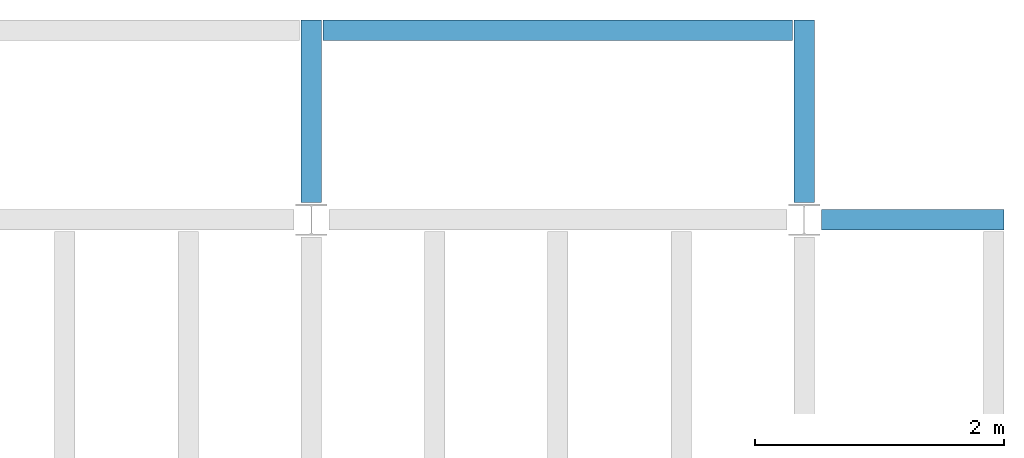
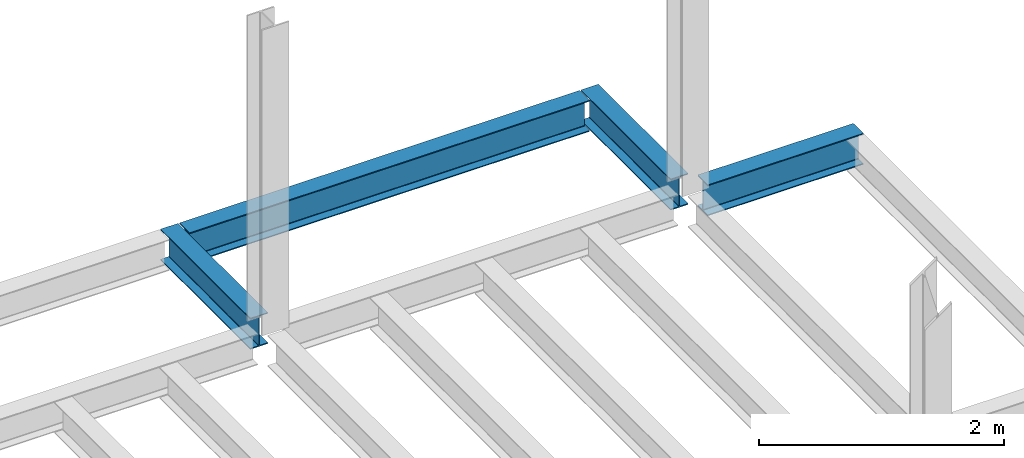
# One storey, part 3 of 3: 4 beams.
"""IFC4 building model written with IfcOpenShell, lengths in feet."""

from ifc_helpers import new_model, entity, si_unit, converted_unit, derived_unit, direction, frame, origin, place, context, subcontext, project, spatial, line, arc, indexed_curve, outline, extrude, source, transform, mapped, material, type_object, type_shapes, element, save


model = new_model("IFC4")

# Units and contexts
model_context = context("Model", 3, precision=0.0001, world=origin(), true_north=direction((6.123233995736766e-17, 1.0)))
plan_context = context("Plan", 3, precision=0.0001, world=origin(), true_north=direction((6.123233995736766e-17, 1.0)))
body_context = subcontext(model_context, "Body", "Model", "MODEL_VIEW")
ifc_project = project(units=[converted_unit("LENGTHUNIT", "FOOT", entity("IfcLengthMeasure", 0.3048), si_unit("LENGTHUNIT", "METRE"), dimensions=[1, 0, 0, 0, 0, 0, 0]), converted_unit("AREAUNIT", "SQUARE FOOT", entity("IfcAreaMeasure", 0.09290304), si_unit("AREAUNIT", "SQUARE_METRE"), dimensions=[2, 0, 0, 0, 0, 0, 0]), converted_unit("PLANEANGLEUNIT", "DEGREE", entity("IfcPlaneAngleMeasure", 0.017453292519943278), si_unit("PLANEANGLEUNIT", "RADIAN"), dimensions=[0, 0, 0, 0, 0, 0, 0]), converted_unit("VOLUMEUNIT", "CUBIC FOOT", entity("IfcVolumeMeasure", 0.028316846592000004), si_unit("VOLUMEUNIT", "CUBIC_METRE"), dimensions=[3, 0, 0, 0, 0, 0, 0]), si_unit("PRESSUREUNIT", "PASCAL"), derived_unit("MASSDENSITYUNIT", [(si_unit("MASSUNIT", "GRAM", prefix="KILO"), 1), (si_unit("LENGTHUNIT", "METRE"), -3)]), derived_unit("VAPORPERMEABILITYUNIT", [(si_unit("LENGTHUNIT", "METRE"), -1), (si_unit("TIMEUNIT", "SECOND"), 1)]), derived_unit("USERDEFINED", [(si_unit("MASSUNIT", "GRAM", prefix="KILO"), 1), (si_unit("LENGTHUNIT", "METRE"), 3), (si_unit("TIMEUNIT", "SECOND"), -3), (si_unit("ELECTRICCURRENTUNIT", "AMPERE"), -2)]), derived_unit("MODULUSOFELASTICITYUNIT", [(si_unit("MASSUNIT", "GRAM", prefix="KILO"), 1), (si_unit("LENGTHUNIT", "METRE"), -1), (si_unit("TIMEUNIT", "SECOND"), -2)]), derived_unit("THERMALEXPANSIONCOEFFICIENTUNIT", [(si_unit("THERMODYNAMICTEMPERATUREUNIT", "KELVIN"), -1)]), derived_unit("SPECIFICHEATCAPACITYUNIT", [(si_unit("TIMEUNIT", "SECOND"), -2), (si_unit("THERMODYNAMICTEMPERATUREUNIT", "KELVIN"), -1), (si_unit("LENGTHUNIT", "METRE"), 2)]), derived_unit("THERMALCONDUCTANCEUNIT", [(si_unit("MASSUNIT", "GRAM", prefix="KILO"), 1), (si_unit("TIMEUNIT", "SECOND"), -3), (si_unit("THERMODYNAMICTEMPERATUREUNIT", "KELVIN"), -1), (si_unit("LENGTHUNIT", "METRE"), 1)])], contexts=[model_context, plan_context])

# Site, building, storey
site_placement = place(None, origin())
site = spatial("IfcSite", under=ifc_project, at=site_placement, CompositionType="ELEMENT")
building_placement = place(site_placement, origin())
building = spatial("IfcBuilding", under=site, at=building_placement, CompositionType="ELEMENT")
storey_placement = place(building_placement, frame((0.0, 0.0, 79.875)))
storey = spatial("IfcBuildingStorey", under=building, at=storey_placement, Name="STR 09", CompositionType="ELEMENT", Elevation=79.875)

# Beams
ifc_material = material(Name="Steel ASTM A992", Category="Metal")
beam_type_1 = type_object("IfcBeamType", Name="W12X26", PredefinedType="JOIST", material=ifc_material)
shared_shape_1 = source(origin(), body_context, "Body", "SweptSolid", [
    extrude(outline(indexed_curve([(0.47666666666666574, -0.2704166666666672), (0.5083333333333351, -0.2704166666666672), (0.5083333333333351, 0.27041666666666686), (0.47666666666666574, 0.27041666666666686), (0.47666666666666574, 0.03458333333333307), (0.46934433619632937, 0.016905663803669473), (0.4516666666666659, 0.00958333333333318), (-0.45166666666666705, 0.00958333333333318), (-0.4693443361963307, 0.01690566380366946), (-0.4766666666666671, 0.03458333333333323), (-0.4766666666666671, 0.27041666666666686), (-0.5083333333333312, 0.27041666666666686), (-0.5083333333333312, -0.27041666666666553), (-0.4766666666666671, -0.27041666666666553), (-0.47666666666666707, -0.034583333333333535), (-0.46934433619633054, -0.016905663803669885), (-0.45166666666666694, -0.00958333333333376), (0.4516666666666658, -0.009583333333333756), (0.4693443361963295, -0.01690566380367015), (0.47666666666666574, -0.0345833333333337)], segments=[line(1, 2, 3, 4, 5), arc(5, 6, 7), line(7, 8), arc(8, 9, 10), line(10, 11, 12, 13, 14, 15), arc(15, 16, 17), line(17, 18), arc(18, 19, 20), line(20, 1)], self_intersect=False)), frame((-2.77041666666672, 0.0, 0.0), z_axis=(1.0, 0.0, 0.0), x_axis=(0.0, 0.0, -1.0)), (0.0, 0.0, 1.0), 4.812083333333389),
])
type_shapes(beam_type_1, [shared_shape_1])
beam_1_placement = place(storey_placement, frame((41.50000000000015, 39.0, -0.50833333333334), z_axis=(0.0, 0.0, 1.0), x_axis=(-1.0, 0.0, 0.0)))
element("IfcBeam", 1, at=beam_1_placement, inside=storey, type_object=beam_type_1, material=ifc_material, Name="W12X26", ObjectType="W Shapes:W12X26", PredefinedType="JOIST", context=body_context, shape_type="MappedRepresentation", body=[
    mapped(shared_shape_1, transform((0.0, 0.0, 0.0), scale=1.0)),
])
beam_type_2 = type_object("IfcBeamType", Name="W12X26", PredefinedType="JOIST", material=ifc_material)
shared_shape_2 = source(origin(), body_context, "Body", "SweptSolid", [
    extrude(outline(indexed_curve([(-0.2704166666666623, -0.5083333333333258), (0.2704166666666694, -0.5083333333333258), (0.2704166666666694, -0.47666666666665947), (0.03458333333333741, -0.4766666666666737), (0.01690566380367642, -0.469344336196329), (0.009583333333338828, -0.451666666666668), (0.009583333333338828, 0.451666666666668), (0.01690566380367642, 0.469344336196329), (0.03458333333333741, 0.4766666666666737), (0.2704166666666694, 0.4766666666666737), (0.2704166666666694, 0.50833333333334), (-0.2704166666666623, 0.50833333333334), (-0.2704166666666623, 0.4766666666666737), (-0.0345833333333303, 0.4766666666666737), (-0.016905663803669313, 0.469344336196329), (-0.009583333333331723, 0.451666666666668), (-0.009583333333331723, -0.451666666666668), (-0.016905663803669313, -0.469344336196329), (-0.0345833333333303, -0.47666666666665947), (-0.2704166666666623, -0.47666666666665947)], segments=[line(1, 2, 3, 4), arc(4, 5, 6), line(6, 7), arc(7, 8, 9), line(9, 10, 11, 12, 13, 14), arc(14, 15, 16), line(16, 17), arc(17, 18, 19), line(19, 20, 1)], self_intersect=False)), frame((39.0, 44.270416666666286, 79.36666666666665), z_axis=(0.0, -1.0, 0.0), x_axis=(-1.0, 0.0, 0.0)), (0.0, 0.0, 1.0), 4.812083333333393),
])
type_shapes(beam_type_2, [shared_shape_2])
beam_2_placement = place(storey_placement, frame((0.0, 0.0, -79.875)))
element("IfcBeam", 2, at=beam_2_placement, inside=storey, type_object=beam_type_2, material=ifc_material, Name="W12X26", ObjectType="W Shapes:W12X26", PredefinedType="JOIST", context=body_context, shape_type="MappedRepresentation", body=[
    mapped(shared_shape_2, transform((0.0, 0.0, 0.0), scale=1.0)),
])
beam_type_3 = type_object("IfcBeamType", Name="W12X26", PredefinedType="JOIST", material=ifc_material)
shared_shape_3 = source(origin(), body_context, "Body", "SweptSolid", [
    extrude(outline(indexed_curve([(-0.2704166666666694, -0.5083333333333258), (0.27041666666666586, -0.5083333333333258), (0.2704166666666623, -0.47666666666665947), (0.034583333333333854, -0.4766666666666737), (0.016905663803669313, -0.469344336196329), (0.009583333333335275, -0.451666666666668), (0.009583333333335275, 0.451666666666668), (0.016905663803669313, 0.469344336196329), (0.034583333333333854, 0.4766666666666737), (0.2704166666666694, 0.4766666666666737), (0.27041666666666586, 0.50833333333334), (-0.27041666666666586, 0.50833333333334), (-0.27041666666666586, 0.4766666666666737), (-0.0345833333333303, 0.4766666666666737), (-0.01690566380366576, 0.469344336196329), (-0.009583333333331723, 0.451666666666668), (-0.009583333333331723, -0.451666666666668), (-0.01690566380366576, -0.469344336196329), (-0.034583333333333854, -0.47666666666665947), (-0.27041666666666586, -0.47666666666665947)], segments=[line(1, 2, 3, 4), arc(4, 5, 6), line(6, 7), arc(7, 8, 9), line(9, 10, 11, 12, 13, 14), arc(14, 15, 16), line(16, 17), arc(17, 18, 19), line(19, 20, 1)], self_intersect=False)), frame((26.0, 44.27041666666632, 79.36666666666665), z_axis=(0.0, -1.0, 0.0), x_axis=(-1.0, 0.0, 0.0)), (0.0, 0.0, 1.0), 4.812083333333393),
])
type_shapes(beam_type_3, [shared_shape_3])
beam_3_placement = place(storey_placement, frame((0.0, 0.0, -79.875)))
element("IfcBeam", 3, at=beam_3_placement, inside=storey, type_object=beam_type_3, material=ifc_material, Name="W12X26", ObjectType="W Shapes:W12X26", PredefinedType="JOIST", context=body_context, shape_type="MappedRepresentation", body=[
    mapped(shared_shape_3, transform((0.0, 0.0, 0.0), scale=1.0)),
])
beam_type_4 = type_object("IfcBeamType", Name="W12X26", PredefinedType="JOIST", material=ifc_material)
shared_shape_4 = source(origin(), body_context, "Body", "SweptSolid", [
    extrude(outline(indexed_curve([(-0.5083333333333258, -0.2704166666666694), (-0.47666666666665947, -0.2704166666666694), (-0.4766666666666737, -0.03458333333333741), (-0.469344336196329, -0.01690566380367642), (-0.451666666666668, -0.009583333333338828), (0.451666666666668, -0.009583333333338828), (0.469344336196329, -0.01690566380367642), (0.4766666666666737, -0.03458333333333741), (0.4766666666666737, -0.2704166666666694), (0.50833333333334, -0.2704166666666694), (0.50833333333334, 0.2704166666666623), (0.4766666666666737, 0.2704166666666623), (0.4766666666666737, 0.0345833333333303), (0.469344336196329, 0.016905663803669313), (0.451666666666668, 0.009583333333331723), (-0.451666666666668, 0.009583333333331723), (-0.469344336196329, 0.016905663803669313), (-0.47666666666665947, 0.0345833333333303), (-0.47666666666665947, 0.2704166666666623), (-0.5083333333333258, 0.2704166666666623)], segments=[line(1, 2, 3), arc(3, 4, 5), line(5, 6), arc(6, 7, 8), line(8, 9, 10, 11, 12, 13), arc(13, 14, 15), line(15, 16), arc(16, 17, 18), line(18, 19, 20, 1)], self_intersect=False)), frame((26.312083333333604, 44.0, 79.36666666666665), z_axis=(1.0, 0.0, 0.0), x_axis=(0.0, 0.0, -1.0)), (0.0, 0.0, 1.0), 12.375833333333079),
])
type_shapes(beam_type_4, [shared_shape_4])
beam_4_placement = place(storey_placement, frame((0.0, 0.0, -79.875)))
element("IfcBeam", 4, at=beam_4_placement, inside=storey, type_object=beam_type_4, material=ifc_material, Name="W Shapes:W12X26", ObjectType="W Shapes:W12X26", PredefinedType="JOIST", context=body_context, shape_type="MappedRepresentation", body=[
    mapped(shared_shape_4, transform((0.0, 0.0, 0.0), scale=1.0)),
])

save(model, "model.ifc")
